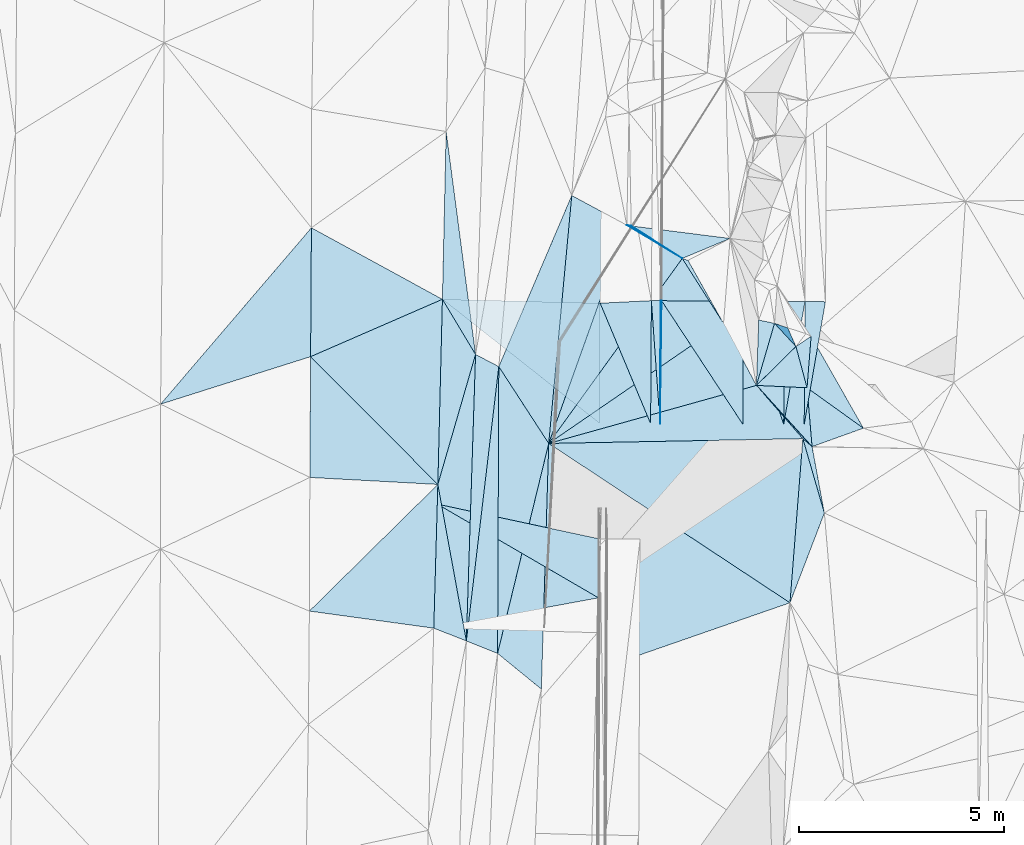
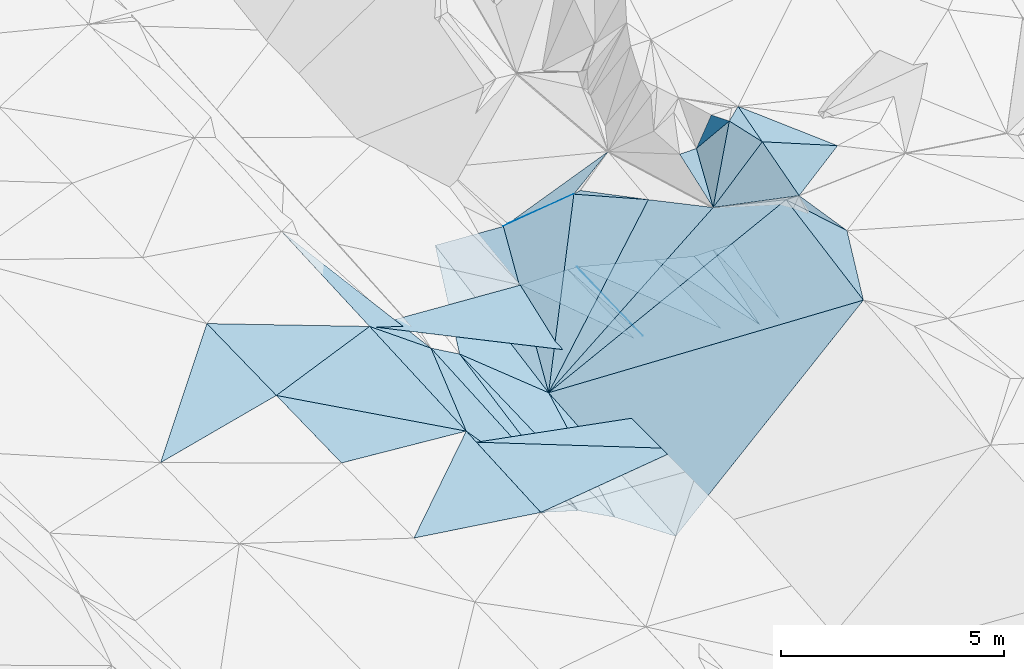
# One storey, part 149 of 275: 45 plates.
"""IFC2X3 building model written with IfcOpenShell, lengths in millimetres."""

from ifc_helpers import new_model, si_unit, frame, origin_with_axes, place, context, subcontext, project, spatial, polyline, outline, extrude, material, type_object, element, save


model = new_model("IFC2X3")

# Units and contexts
model_context = context("Model", 3, precision=1e-05, world=origin_with_axes())
body_context = subcontext(model_context, "Body", "Model", "MODEL_VIEW")
ifc_project = project(units=[si_unit("LENGTHUNIT", "METRE", prefix="MILLI"), si_unit("AREAUNIT", "SQUARE_METRE"), si_unit("VOLUMEUNIT", "CUBIC_METRE"), si_unit("MASSUNIT", "GRAM", prefix="KILO"), si_unit("TIMEUNIT", "SECOND"), si_unit("PLANEANGLEUNIT", "RADIAN"), si_unit("SOLIDANGLEUNIT", "STERADIAN"), si_unit("THERMODYNAMICTEMPERATUREUNIT", "DEGREE_CELSIUS"), si_unit("LUMINOUSINTENSITYUNIT", "LUMEN")], contexts=[model_context])

# Site, building, storey
site_placement = place(None, origin_with_axes())
site = spatial("IfcSite", under=ifc_project, at=site_placement, CompositionType="ELEMENT")
building_placement = place(site_placement, origin_with_axes())
building = spatial("IfcBuilding", under=site, at=building_placement, Name="Undefined", CompositionType="ELEMENT")
storey_placement = place(building_placement, origin_with_axes())
storey = spatial("IfcBuildingStorey", under=building, at=storey_placement, Name="Undefined", CompositionType="ELEMENT", Elevation=0.0)

# Plates
ifc_material = material()
plate_type_1 = type_object("IfcPlateType", PredefinedType="NOTDEFINED")
plate_1_placement = place(storey_placement, frame((-61479.0299583362, 116961.351164867, 43422.3183398899), z_axis=(-0.0329025764102247, 0.0165529434712929, -0.999321480069355), x_axis=(0.977091128612706, -0.209814882884495, -0.0356460559741826)))
element("IfcPlate", 1, at=plate_1_placement, inside=storey, type_object=plate_type_1, material=ifc_material, Name="00_PR", context=body_context, shape_type="SweptSolid", body=[
    extrude(outline(polyline([(0.0, 0.0), (4036.2109375, -5.28234522789717e-09), (4332.94677734375, 1411.77331542969), (0.0, 0.0)])), frame((-8.85201319254618e-08, 2.18876761149539e-07, -0.5000001331573), z_axis=(0.0, 0.0, 1.0), x_axis=(1.0, 0.0, 0.0)), (0.0, 0.0, 1.0), 1.0),
])
plate_type_2 = type_object("IfcPlateType", PredefinedType="NOTDEFINED")
plate_2_placement = place(storey_placement, frame((-57542.1886862768, 114672.084322915, 43254.7783387415), z_axis=(-0.031873229045309, 0.018323285685146, -0.999323948713292), x_axis=(-0.983091266962488, -0.180957062021271, 0.0280375199816376)))
element("IfcPlate", 2, at=plate_2_placement, inside=storey, type_object=plate_type_2, material=ifc_material, Name="00_PR", context=body_context, shape_type="SweptSolid", body=[
    extrude(outline(polyline([(0.0, 0.0), (4091.7314453125, -9.50240064412355e-09), (3460.7119140625, 2964.96264648438), (0.0, 0.0)])), frame((-8.85201319254618e-08, 2.18876761149539e-07, -0.5000001331573), z_axis=(0.0, 0.0, 1.0), x_axis=(1.0, 0.0, 0.0)), (0.0, 0.0, 1.0), 1.0),
])
plate_type_3 = type_object("IfcPlateType", PredefinedType="NOTDEFINED")
plate_3_placement = place(storey_placement, frame((-56039.4487513482, 118925.746862372, 43232.5547125161), z_axis=(-0.049807936925527, 0.0189963330926102, -0.998578143536227), x_axis=(0.00611291887596567, 0.999806175663685, 0.0187147890068687)))
element("IfcPlate", 3, at=plate_3_placement, inside=storey, type_object=plate_type_3, material=ifc_material, Name="00_PR", context=body_context, shape_type="SweptSolid", body=[
    extrude(outline(polyline([(0.0, 0.0), (3002.86572265625, -1.22745404951274e-08), (3002.84252929688, 20.0255527496338), (0.0, 0.0)])), frame((-8.85201319254618e-08, 2.18876761149539e-07, -0.5000001331573), z_axis=(0.0, 0.0, 1.0), x_axis=(1.0, 0.0, 0.0)), (0.0, 0.0, 1.0), 1.0),
])
plate_type_4 = type_object("IfcPlateType", PredefinedType="NOTDEFINED")
plate_4_placement = place(storey_placement, frame((-52326.8632892654, 118364.443197118, 46106.6760373091), z_axis=(0.69734426175413, 0.306468340372365, -0.647910593329046), x_axis=(-0.675138660117306, 0.584351626503173, -0.450245451079859)))
element("IfcPlate", 4, at=plate_4_placement, inside=storey, type_object=plate_type_4, material=ifc_material, Name="00", context=body_context, shape_type="SweptSolid", body=[
    extrude(outline(polyline([(0.0, 0.0), (333.151611328125, 4.94765117764473e-10), (2131.0087890625, 332.806030273438), (0.0, 0.0)])), frame((-8.85201319254618e-08, 2.18876761149539e-07, -0.5000001331573), z_axis=(0.0, 0.0, 1.0), x_axis=(1.0, 0.0, 0.0)), (0.0, 0.0, 1.0), 1.0),
])
plate_type_5 = type_object("IfcPlateType", PredefinedType="NOTDEFINED")
plate_5_placement = place(storey_placement, frame((-52519.4841683663, 118905.108407117, 42481.5540900035), z_axis=(0.000119182844558376, 0.0187254283032671, -0.999824656692517), x_axis=(0.00611306091589654, 0.999805968495159, 0.0187258069971578)))
element("IfcPlate", 5, at=plate_5_placement, inside=storey, type_object=plate_type_5, material=ifc_material, Name="00_PR", context=body_context, shape_type="SweptSolid", body=[
    extrude(outline(polyline([(0.0, 0.0), (3001.09887695313, 1.39043550007045e-08), (3000.97387695313, 499.999359130859), (0.0, 0.0)])), frame((-8.85201319254618e-08, 2.18876761149539e-07, -0.5000001331573), z_axis=(0.0, 0.0, 1.0), x_axis=(1.0, 0.0, 0.0)), (0.0, 0.0, 1.0), 1.0),
])
plate_6_placement = place(storey_placement, frame((-53019.475938482, 118908.03920349, 42481.5540895607), z_axis=(0.000119191142338227, 0.0187238562221799, -0.999824686133346), x_axis=(0.00611294987966392, 0.999805998615529, 0.0187242349956666)))
element("IfcPlate", 6, at=plate_6_placement, inside=storey, type_object=plate_type_5, material=ifc_material, Name="00_PR", context=body_context, shape_type="SweptSolid", body=[
    extrude(outline(polyline([(0.0, 0.0), (3001.35107421875, -6.88305590301752e-09), (3001.22509765625, 500.000671386719), (0.0, 0.0)])), frame((-8.85201319254618e-08, 2.18876761149539e-07, -0.5000001331573), z_axis=(0.0, 0.0, 1.0), x_axis=(1.0, 0.0, 0.0)), (0.0, 0.0, 1.0), 1.0),
])
plate_type_6 = type_object("IfcPlateType", PredefinedType="NOTDEFINED")
plate_7_placement = place(storey_placement, frame((-56021.0924717084, 121928.030640684, 43288.7527128769), z_axis=(-0.0498090880856332, 0.0189963390593034, -0.998578086003504), x_axis=(-0.00611291892662742, -0.999806175663324, -0.0187147890096435)))
element("IfcPlate", 7, at=plate_7_placement, inside=storey, type_object=plate_type_6, material=ifc_material, Name="00_PR", context=body_context, shape_type="SweptSolid", body=[
    extrude(outline(polyline([(0.0, 0.0), (3002.86572265625, -1.22745404951274e-08), (-0.273052126169205, 230.286712646484), (0.0, 0.0)])), frame((-8.85201319254618e-08, 2.18876761149539e-07, -0.5000001331573), z_axis=(0.0, 0.0, 1.0), x_axis=(1.0, 0.0, 0.0)), (0.0, 0.0, 1.0), 1.0),
])
plate_type_7 = type_object("IfcPlateType", PredefinedType="NOTDEFINED")
plate_8_placement = place(storey_placement, frame((-53001.2500793911, 121908.808364038, 42537.76701002), z_axis=(-0.242375710257185, 0.0196476411927777, -0.969983497422964), x_axis=(-0.00611294987499495, -0.999805998615407, -0.0187242350037056)))
element("IfcPlate", 8, at=plate_8_placement, inside=storey, type_object=plate_type_7, material=ifc_material, Name="00_PR", context=body_context, shape_type="SweptSolid", body=[
    extrude(outline(polyline([(0.0, 0.0), (3001.35107421875, -6.88305590301752e-09), (-4.93210220336914, 1030.7646484375), (0.0, 0.0)])), frame((-8.85201319254618e-08, 2.18876761149539e-07, -0.5000001331573), z_axis=(0.0, 0.0, 1.0), x_axis=(1.0, 0.0, 0.0)), (0.0, 0.0, 1.0), 1.0),
])
plate_type_8 = type_object("IfcPlateType", PredefinedType="NOTDEFINED")
plate_9_placement = place(storey_placement, frame((-56001.1885805339, 121927.90407813, 43287.767009768), z_axis=(-0.242375843046882, 0.0196446149122441, -0.969983525536523), x_axis=(0.970122823768883, -0.00617525688061389, -0.242535714906376)))
element("IfcPlate", 9, at=plate_9_placement, inside=storey, type_object=plate_type_8, material=ifc_material, Name="00_PR", context=body_context, shape_type="SweptSolid", body=[
    extrude(outline(polyline([(0.0, 0.0), (2061.55200195313, 4.42378222942352e-09), (2075.91357421875, 3001.81860351563), (0.0, 0.0)])), frame((-8.85201319254618e-08, 2.18876761149539e-07, -0.5000001331573), z_axis=(0.0, 0.0, 1.0), x_axis=(1.0, 0.0, 0.0)), (0.0, 0.0, 1.0), 1.0),
])
plate_type_9 = type_object("IfcPlateType", PredefinedType="NOTDEFINED")
plate_10_placement = place(storey_placement, frame((-56251.0828946079, 121929.494670942, 43300.2525091687), z_axis=(-0.0408545503344278, 0.018948494490378, -0.998985415445851), x_axis=(-0.00611291892662742, -0.999806175663324, -0.0187147890096435)))
element("IfcPlate", 10, at=plate_10_placement, inside=storey, type_object=plate_type_9, material=ifc_material, Name="00_PR", context=body_context, shape_type="SweptSolid", body=[
    extrude(outline(polyline([(0.0, 0.0), (3002.98217773438, -1.09139364212751e-08), (68.4931945800781, 1251.06701660156), (0.0, 0.0)])), frame((-8.85201319254618e-08, 2.18876761149539e-07, -0.5000001331573), z_axis=(0.0, 0.0, 1.0), x_axis=(1.0, 0.0, 0.0)), (0.0, 0.0, 1.0), 1.0),
])
plate_type_10 = type_object("IfcPlateType", PredefinedType="NOTDEFINED")
plate_11_placement = place(storey_placement, frame((-61354.0244489155, 121962.646774277, 43509.5005061315), z_axis=(-0.0408421664010008, 0.0187129023914797, -0.998990362680121), x_axis=(0.998843591986472, -0.0246173179426941, -0.0412972929484572)))
element("IfcPlate", 11, at=plate_11_placement, inside=storey, type_object=plate_type_10, material=ifc_material, Name="00_PR", context=body_context, shape_type="SweptSolid", body=[
    extrude(outline(polyline([(0.0, 0.0), (3856.98413085938, -1.36642483994365e-08), (3913.53466796875, 2933.28540039063), (0.0, 0.0)])), frame((-8.85201319254618e-08, 2.18876761149539e-07, -0.5000001331573), z_axis=(0.0, 0.0, 1.0), x_axis=(1.0, 0.0, 0.0)), (0.0, 0.0, 1.0), 1.0),
])
plate_type_11 = type_object("IfcPlateType", PredefinedType="NOTDEFINED")
plate_12_placement = place(storey_placement, frame((-53243.7252866068, 121375.65325235, 45889.7370056535), z_axis=(0.848332088537827, -0.0605051250467132, -0.525996005118034), x_axis=(0.439041433956534, -0.474876256974329, 0.762715648083505)))
element("IfcPlate", 12, at=plate_12_placement, inside=storey, type_object=plate_type_11, material=ifc_material, Name="00", context=body_context, shape_type="SweptSolid", body=[
    extrude(outline(polyline([(0.0, 0.0), (1193.10522460938, 8.58562998473644e-10), (115.672950744629, 1664.21655273438), (0.0, 0.0)])), frame((-8.85201319254618e-08, 2.18876761149539e-07, -0.5000001331573), z_axis=(0.0, 0.0, 1.0), x_axis=(1.0, 0.0, 0.0)), (0.0, 0.0, 1.0), 1.0),
])
plate_type_12 = type_object("IfcPlateType", PredefinedType="NOTDEFINED")
plate_13_placement = place(storey_placement, frame((-56850.7797211205, 123771.838198348, 43569.5740240012), z_axis=(0.517243051542686, -0.0818251017264593, -0.851917999785346), x_axis=(0.745046776028475, -0.446782143451001, 0.495268631979561)))
element("IfcPlate", 13, at=plate_13_placement, inside=storey, type_object=plate_type_12, material=ifc_material, Name="00", context=body_context, shape_type="SweptSolid", body=[
    extrude(outline(polyline([(0.0, 0.0), (1817.19567871094, -3.20869730785489e-09), (640.206237792969, 5660.76513671875), (0.0, 0.0)])), frame((-8.85201319254618e-08, 2.18876761149539e-07, -0.5000001331573), z_axis=(0.0, 0.0, 1.0), x_axis=(1.0, 0.0, 0.0)), (0.0, 0.0, 1.0), 1.0),
])
plate_type_13 = type_object("IfcPlateType", PredefinedType="NOTDEFINED")
plate_14_placement = place(storey_placement, frame((-55496.9757153138, 122959.791961986, 44469.57160676), z_axis=(0.333751542116307, -0.393172210884728, -0.856752893618109), x_axis=(-0.745046776033763, 0.446782143438528, -0.495268631982857)))
element("IfcPlate", 14, at=plate_14_placement, inside=storey, type_object=plate_type_13, material=ifc_material, Name="00", context=body_context, shape_type="SweptSolid", body=[
    extrude(outline(polyline([(0.0, 0.0), (1817.19567871094, -3.20869730785489e-09), (1704.76965332031, 39.5018882751465), (0.0, 0.0)])), frame((-8.85201319254618e-08, 2.18876761149539e-07, -0.5000001331573), z_axis=(0.0, 0.0, 1.0), x_axis=(1.0, 0.0, 0.0)), (0.0, 0.0, 1.0), 1.0),
])
plate_type_14 = type_object("IfcPlateType", PredefinedType="NOTDEFINED")
plate_15_placement = place(storey_placement, frame((-53685.6383279684, 119859.603387808, 45351.5511689026), z_axis=(0.439352055737474, -0.0345783696349237, -0.89764921181531), x_axis=(0.620062306166801, -0.711360945492197, 0.330890226056248)))
element("IfcPlate", 15, at=plate_15_placement, inside=storey, type_object=plate_type_14, material=ifc_material, Name="00", context=body_context, shape_type="SweptSolid", body=[
    extrude(outline(polyline([(0.0, 0.0), (1828.40100097656, -8.21455614641309e-09), (-2940.55419921875, 4998.3291015625), (0.0, 0.0)])), frame((-8.85201319254618e-08, 2.18876761149539e-07, -0.5000001331573), z_axis=(0.0, 0.0, 1.0), x_axis=(1.0, 0.0, 0.0)), (0.0, 0.0, 1.0), 1.0),
])
plate_type_15 = type_object("IfcPlateType", PredefinedType="NOTDEFINED")
plate_16_placement = place(storey_placement, frame((-61354.0255894502, 121962.646826846, 43509.500540234), z_axis=(-0.0428705906760543, 0.0187319073889793, -0.998905014553765), x_axis=(0.514898006455965, -0.856401789479594, -0.0381578029218377)))
element("IfcPlate", 16, at=plate_16_placement, inside=storey, type_object=plate_type_15, material=ifc_material, Name="00", context=body_context, shape_type="SweptSolid", body=[
    extrude(outline(polyline([(0.0, 0.0), (1572.41760253906, 2.65936250798404e-09), (3817.580078125, 2426.00122070313), (0.0, 0.0)])), frame((-8.85201319254618e-08, 2.18876761149539e-07, -0.5000001331573), z_axis=(0.0, 0.0, 1.0), x_axis=(1.0, 0.0, 0.0)), (0.0, 0.0, 1.0), 1.0),
])
plate_type_16 = type_object("IfcPlateType", PredefinedType="NOTDEFINED")
plate_17_placement = place(storey_placement, frame((-54328.5172688935, 123447.989110163, 44928.5668156013), z_axis=(0.439464793612823, -0.23726843262176, -0.866356962259814), x_axis=(-0.867483975671943, -0.362404622485834, -0.340785037161698)))
element("IfcPlate", 17, at=plate_17_placement, inside=storey, type_object=plate_type_16, material=ifc_material, Name="00", context=body_context, shape_type="SweptSolid", body=[
    extrude(outline(polyline([(0.0, 0.0), (1346.89013671875, 4.43833414465189e-09), (2431.05419921875, 1316.2021484375), (0.0, 0.0)])), frame((-8.85201319254618e-08, 2.18876761149539e-07, -0.5000001331573), z_axis=(0.0, 0.0, 1.0), x_axis=(1.0, 0.0, 0.0)), (0.0, 0.0, 1.0), 1.0),
])
plate_type_17 = type_object("IfcPlateType", PredefinedType="NOTDEFINED")
plate_18_placement = place(storey_placement, frame((-60768.8324343098, 113619.908639251, 43329.5214232664), z_axis=(-0.288471439383598, 0.0256666360911163, -0.957144426119549), x_axis=(0.0320421244614618, 0.9993395254752, 0.0171410350620224)))
element("IfcPlate", 18, at=plate_18_placement, inside=storey, type_object=plate_type_17, material=ifc_material, Name="00", context=body_context, shape_type="SweptSolid", body=[
    extrude(outline(polyline([(0.0, 0.0), (7000.744140625, 3.45753505825996e-08), (6719.1708984375, 602.461242675781), (0.0, 0.0)])), frame((-8.85201319254618e-08, 2.18876761149539e-07, -0.5000001331573), z_axis=(0.0, 0.0, 1.0), x_axis=(1.0, 0.0, 0.0)), (0.0, 0.0, 1.0), 1.0),
])
plate_type_18 = type_object("IfcPlateType", PredefinedType="NOTDEFINED")
plate_19_placement = place(storey_placement, frame((-58757.8588323389, 118442.712989502, 42923.5467483449), z_axis=(0.422201868177247, 0.0054583395439276, -0.906485404756782), x_axis=(0.563995640327622, 0.781288582001737, 0.267389359035006)))
element("IfcPlate", 19, at=plate_19_placement, inside=storey, type_object=plate_type_18, material=ifc_material, Name="00", context=body_context, shape_type="SweptSolid", body=[
    extrude(outline(polyline([(0.0, 0.0), (5781.83056640625, -1.91066646948457e-08), (5232.783203125, 1856.91857910156), (0.0, 0.0)])), frame((-8.85201319254618e-08, 2.18876761149539e-07, -0.5000001331573), z_axis=(0.0, 0.0, 1.0), x_axis=(1.0, 0.0, 0.0)), (0.0, 0.0, 1.0), 1.0),
])
plate_type_19 = type_object("IfcPlateType", PredefinedType="NOTDEFINED")
plate_20_placement = place(storey_placement, frame((-58195.2576853498, 124497.366959812, 43083.5115053436), z_axis=(-0.208550369623353, 0.0452068689817732, -0.976966264682065), x_axis=(-0.0925415685314663, -0.995361334486497, -0.0263034580045142)))
element("IfcPlate", 20, at=plate_20_placement, inside=storey, type_object=plate_type_19, material=ifc_material, Name="00", context=body_context, shape_type="SweptSolid", body=[
    extrude(outline(polyline([(0.0, 0.0), (6082.8505859375, -4.78758011013269e-09), (4318.79541015625, 1419.48449707031), (0.0, 0.0)])), frame((-8.85201319254618e-08, 2.18876761149539e-07, -0.5000001331573), z_axis=(0.0, 0.0, 1.0), x_axis=(1.0, 0.0, 0.0)), (0.0, 0.0, 1.0), 1.0),
])
plate_type_20 = type_object("IfcPlateType", PredefinedType="NOTDEFINED")
plate_21_placement = place(storey_placement, frame((-52026.585026435, 116742.306012551, 46029.5150487687), z_axis=(0.241580302858253, 0.0308979401134254, -0.96988879494902), x_axis=(-0.355493649307203, -0.927189514081666, -0.118084166081877)))
element("IfcPlate", 21, at=plate_21_placement, inside=storey, type_object=plate_type_20, material=ifc_material, Name="00", context=body_context, shape_type="SweptSolid", body=[
    extrude(outline(polyline([(0.0, 0.0), (2362.72143554688, -1.17579475045204e-08), (-1488.99694824219, 1168.16491699219), (0.0, 0.0)])), frame((-8.85201319254618e-08, 2.18876761149539e-07, -0.5000001331573), z_axis=(0.0, 0.0, 1.0), x_axis=(1.0, 0.0, 0.0)), (0.0, 0.0, 1.0), 1.0),
])
plate_type_21 = type_object("IfcPlateType", PredefinedType="NOTDEFINED")
plate_22_placement = place(storey_placement, frame((-61465.4521778604, 117441.520184333, 43429.5005394583), z_axis=(-0.0430301649422816, 0.0182932295498284, -0.998906283220642), x_axis=(0.179300305610219, -0.983457755689404, -0.0257340860036582)))
element("IfcPlate", 22, at=plate_22_placement, inside=storey, type_object=plate_type_21, material=ifc_material, Name="00", context=body_context, shape_type="SweptSolid", body=[
    extrude(outline(polyline([(0.0, 0.0), (3885.89672851563, 1.0113581083715e-08), (3435.54418945313, 727.7607421875), (0.0, 0.0)])), frame((-8.85201319254618e-08, 2.18876761149539e-07, -0.5000001331573), z_axis=(0.0, 0.0, 1.0), x_axis=(1.0, 0.0, 0.0)), (0.0, 0.0, 1.0), 1.0),
])
plate_type_22 = type_object("IfcPlateType", PredefinedType="NOTDEFINED")
plate_23_placement = place(storey_placement, frame((-61262.7224877274, 126059.398080829, 43589.5004991977), z_axis=(-0.0400996297586528, 0.0204015742651627, -0.998987385035828), x_axis=(0.130787930620647, -0.991082628668625, -0.0254900050069909)))
element("IfcPlate", 23, at=plate_23_placement, inside=storey, type_object=plate_type_22, material=ifc_material, Name="00", context=body_context, shape_type="SweptSolid", body=[
    extrude(outline(polyline([(0.0, 0.0), (5492.34912109375, -3.39496182277799e-08), (4050.31616210938, 626.927917480469), (0.0, 0.0)])), frame((-8.85201319254618e-08, 2.18876761149539e-07, -0.5000001331573), z_axis=(0.0, 0.0, 1.0), x_axis=(1.0, 0.0, 0.0)), (0.0, 0.0, 1.0), 1.0),
])
plate_type_23 = type_object("IfcPlateType", PredefinedType="NOTDEFINED")
plate_24_placement = place(storey_placement, frame((-52350.1986471895, 121060.248840798, 46919.5063526397), z_axis=(0.0973306377261847, 0.125701945800875, -0.987282010259322), x_axis=(0.493403001659141, -0.867601001971799, -0.0618221589018055)))
element("IfcPlate", 24, at=plate_24_placement, inside=storey, type_object=plate_type_23, material=ifc_material, Name="00", context=body_context, shape_type="SweptSolid", body=[
    extrude(outline(polyline([(0.0, 0.0), (2588.06884765625, -1.41735654324293e-08), (1052.48364257813, 716.434387207031), (0.0, 0.0)])), frame((-8.85201319254618e-08, 2.18876761149539e-07, -0.5000001331573), z_axis=(0.0, 0.0, 1.0), x_axis=(1.0, 0.0, 0.0)), (0.0, 0.0, 1.0), 1.0),
])
plate_type_24 = type_object("IfcPlateType", PredefinedType="NOTDEFINED")
plate_25_placement = place(storey_placement, frame((-53243.7062194962, 121375.867140537, 45889.8592003227), z_axis=(0.88646026113915, 0.367268047516023, -0.281606794475699), x_axis=(0.344390943856289, -0.116999202989138, 0.931507415048147)))
element("IfcPlate", 25, at=plate_25_placement, inside=storey, type_object=plate_type_24, material=ifc_material, Name="00", context=body_context, shape_type="SweptSolid", body=[
    extrude(outline(polyline([(0.0, 0.0), (933.970031738281, 5.23868948221207e-10), (1094.36059570313, 475.262939453125), (0.0, 0.0)])), frame((-8.85201319254618e-08, 2.18876761149539e-07, -0.5000001331573), z_axis=(0.0, 0.0, 1.0), x_axis=(1.0, 0.0, 0.0)), (0.0, 0.0, 1.0), 1.0),
])
plate_type_25 = type_object("IfcPlateType", PredefinedType="NOTDEFINED")
plate_26_placement = place(storey_placement, frame((-53685.7448533624, 119859.753933926, 45351.531543104), z_axis=(0.226028689532777, 0.266627872733768, -0.936920812550112), x_axis=(0.0336519708339458, 0.959100542387471, 0.281058169159074)))
element("IfcPlate", 26, at=plate_26_placement, inside=storey, type_object=plate_type_25, material=ifc_material, Name="00", context=body_context, shape_type="SweptSolid", body=[
    extrude(outline(polyline([(0.0, 0.0), (1665.1357421875, 5.03496266901493e-09), (1620.13037109375, 397.711608886719), (0.0, 0.0)])), frame((-8.85201319254618e-08, 2.18876761149539e-07, -0.5000001331573), z_axis=(0.0, 0.0, 1.0), x_axis=(1.0, 0.0, 0.0)), (0.0, 0.0, 1.0), 1.0),
])
plate_type_26 = type_object("IfcPlateType", PredefinedType="NOTDEFINED")
plate_27_placement = place(storey_placement, frame((-52719.9598177586, 120809.220537808, 46799.6802863823), z_axis=(0.734036682068431, 0.228720384971688, -0.639435012238438), x_axis=(0.258862859251788, -0.964725005363351, -0.047913298014975)))
element("IfcPlate", 27, at=plate_27_placement, inside=storey, type_object=plate_type_26, material=ifc_material, Name="00", context=body_context, shape_type="SweptSolid", body=[
    extrude(outline(polyline([(0.0, 0.0), (1043.55163574219, -4.10000211559236e-09), (735.430786132813, 1841.09167480469), (0.0, 0.0)])), frame((-8.85201319254618e-08, 2.18876761149539e-07, -0.5000001331573), z_axis=(0.0, 0.0, 1.0), x_axis=(1.0, 0.0, 0.0)), (0.0, 0.0, 1.0), 1.0),
])
plate_type_27 = type_object("IfcPlateType", PredefinedType="NOTDEFINED")
plate_28_placement = place(storey_placement, frame((-52450.0397007069, 119802.571127342, 46749.5696102747), z_axis=(0.300755742631578, 0.410598995128739, -0.860787109843891), x_axis=(0.812576607038931, -0.582824527847819, 0.00590147710885984)))
element("IfcPlate", 28, at=plate_28_placement, inside=storey, type_object=plate_type_27, material=ifc_material, Name="00", context=body_context, shape_type="SweptSolid", body=[
    extrude(outline(polyline([(0.0, 0.0), (1694.49108886719, -1.13504938781261e-09), (934.280517578125, 1274.26647949219), (0.0, 0.0)])), frame((-8.85201319254618e-08, 2.18876761149539e-07, -0.5000001331573), z_axis=(0.0, 0.0, 1.0), x_axis=(1.0, 0.0, 0.0)), (0.0, 0.0, 1.0), 1.0),
])
plate_type_28 = type_object("IfcPlateType", PredefinedType="NOTDEFINED")
plate_29_placement = place(storey_placement, frame((-52326.8556214931, 118364.458065837, 46106.6920447028), z_axis=(0.712415985499923, 0.336315452038892, -0.615918322770194), x_axis=(-0.629924405906405, 0.693297062758218, -0.350049175994302)))
element("IfcPlate", 29, at=plate_29_placement, inside=storey, type_object=plate_type_28, material=ifc_material, Name="00", context=body_context, shape_type="SweptSolid", body=[
    extrude(outline(polyline([(0.0, 0.0), (2156.83984375, 8.01810529083014e-09), (849.399169921875, 1332.34985351563), (0.0, 0.0)])), frame((-8.85201319254618e-08, 2.18876761149539e-07, -0.5000001331573), z_axis=(0.0, 0.0, 1.0), x_axis=(1.0, 0.0, 0.0)), (0.0, 0.0, 1.0), 1.0),
])
plate_type_29 = type_object("IfcPlateType", PredefinedType="NOTDEFINED")
plate_30_placement = place(storey_placement, frame((-58758.1857939334, 118442.724899088, 42923.5138266057), z_axis=(-0.231728705573477, 0.029296136826433, -0.972339212096421), x_axis=(-0.236449249359129, -0.971266208670962, 0.0270869778941756)))
element("IfcPlate", 30, at=plate_30_placement, inside=storey, type_object=plate_type_29, material=ifc_material, Name="00", context=body_context, shape_type="SweptSolid", body=[
    extrude(outline(polyline([(0.0, 0.0), (5279.28955078125, 4.52564563602209e-09), (-1524.921875, 1673.75012207031), (0.0, 0.0)])), frame((-8.85201319254618e-08, 2.18876761149539e-07, -0.5000001331573), z_axis=(0.0, 0.0, 1.0), x_axis=(1.0, 0.0, 0.0)), (0.0, 0.0, 1.0), 1.0),
])
plate_type_30 = type_object("IfcPlateType", PredefinedType="NOTDEFINED")
plate_31_placement = place(storey_placement, frame((-58758.2151605746, 118442.732285804, 42923.5220519762), z_axis=(-0.290441751418028, 0.0440485626356174, -0.955878294116445), x_axis=(-0.0298523394217043, -0.998870791680332, -0.0369591579849714)))
element("IfcPlate", 31, at=plate_31_placement, inside=storey, type_object=plate_type_30, material=ifc_material, Name="00", context=body_context, shape_type="SweptSolid", body=[
    extrude(outline(polyline([(0.0, 0.0), (6006.63037109375, -2.18278728425503e-09), (5153.78466796875, 1144.29187011719), (0.0, 0.0)])), frame((-8.85201319254618e-08, 2.18876761149539e-07, -0.5000001331573), z_axis=(0.0, 0.0, 1.0), x_axis=(1.0, 0.0, 0.0)), (0.0, 0.0, 1.0), 1.0),
])
plate_type_31 = type_object("IfcPlateType", PredefinedType="NOTDEFINED")
plate_32_placement = place(storey_placement, frame((-61465.4493738549, 117441.519629671, 43429.5004176427), z_axis=(-0.0374184731790921, 0.0171782847789726, -0.999152022665719), x_axis=(-0.997780888082568, 0.0544623014134893, 0.0383034868113674)))
element("IfcPlate", 32, at=plate_32_placement, inside=storey, type_object=plate_type_31, material=ifc_material, Name="00", context=body_context, shape_type="SweptSolid", body=[
    extrude(outline(polyline([(0.0, 0.0), (3132.8740234375, 6.43194653093815e-09), (3276.48022460938, 2946.53637695313), (0.0, 0.0)])), frame((-8.85201319254618e-08, 2.18876761149539e-07, -0.5000001331573), z_axis=(0.0, 0.0, 1.0), x_axis=(1.0, 0.0, 0.0)), (0.0, 0.0, 1.0), 1.0),
])
plate_type_32 = type_object("IfcPlateType", PredefinedType="NOTDEFINED")
plate_33_placement = place(storey_placement, frame((-64572.3801652994, 120561.692864608, 43599.5004012493), z_axis=(-0.0360242658032513, 0.018568011957981, -0.999178403091893), x_axis=(0.916594973307161, 0.398994543834439, -0.0256321848150462)))
element("IfcPlate", 33, at=plate_33_placement, inside=storey, type_object=plate_type_32, material=ifc_material, Name="00", context=body_context, shape_type="SweptSolid", body=[
    extrude(outline(polyline([(0.0, 0.0), (3511.21069335938, 8.00355337560177e-09), (1607.22338867188, 4102.9541015625), (0.0, 0.0)])), frame((-8.85201319254618e-08, 2.18876761149539e-07, -0.5000001331573), z_axis=(0.0, 0.0, 1.0), x_axis=(1.0, 0.0, 0.0)), (0.0, 0.0, 1.0), 1.0),
])
plate_type_33 = type_object("IfcPlateType", PredefinedType="NOTDEFINED")
plate_34_placement = place(storey_placement, frame((-60544.3904820501, 120616.025483916, 43449.5005205821), z_axis=(-0.0420053418137465, 0.0184811227137273, -0.998946444691782), x_axis=(-0.0320421244554766, -0.999339525475748, -0.0171410350412605)))
element("IfcPlate", 34, at=plate_34_placement, inside=storey, type_object=plate_type_33, material=ifc_material, Name="00", context=body_context, shape_type="SweptSolid", body=[
    extrude(outline(polyline([(0.0, 0.0), (7000.744140625, 3.45753505825996e-08), (3202.26416015625, 819.598449707031), (0.0, 0.0)])), frame((-8.85201319254618e-08, 2.18876761149539e-07, -0.5000001331573), z_axis=(0.0, 0.0, 1.0), x_axis=(1.0, 0.0, 0.0)), (0.0, 0.0, 1.0), 1.0),
])
plate_type_34 = type_object("IfcPlateType", PredefinedType="NOTDEFINED")
plate_35_placement = place(storey_placement, frame((-52551.8170233807, 118559.044585931, 45956.6222937095), z_axis=(0.636945524503394, 0.153866674035246, -0.755397541322732), x_axis=(0.675138660108836, -0.584351626513641, 0.450245451078973)))
element("IfcPlate", 35, at=plate_35_placement, inside=storey, type_object=plate_type_34, material=ifc_material, Name="00", context=body_context, shape_type="SweptSolid", body=[
    extrude(outline(polyline([(0.0, 0.0), (333.151611328125, 4.94765117764473e-10), (1449.18395996094, 1217.20446777344), (0.0, 0.0)])), frame((-8.85201319254618e-08, 2.18876761149539e-07, -0.5000001331573), z_axis=(0.0, 0.0, 1.0), x_axis=(1.0, 0.0, 0.0)), (0.0, 0.0, 1.0), 1.0),
])
plate_type_35 = type_object("IfcPlateType", PredefinedType="NOTDEFINED")
plate_36_placement = place(storey_placement, frame((-54488.7554479605, 121372.025709987, 44929.5501400306), z_axis=(0.436103012818509, -0.0194566655690106, -0.899686390013517), x_axis=(0.455370123612511, -0.857545972877653, 0.239275897077926)))
element("IfcPlate", 36, at=plate_36_placement, inside=storey, type_object=plate_type_35, material=ifc_material, Name="00", context=body_context, shape_type="SweptSolid", body=[
    extrude(outline(polyline([(0.0, 0.0), (1763.65441894531, -9.42964106798172e-09), (88.0246124267578, 5551.7939453125), (0.0, 0.0)])), frame((-8.85201319254618e-08, 2.18876761149539e-07, -0.5000001331573), z_axis=(0.0, 0.0, 1.0), x_axis=(1.0, 0.0, 0.0)), (0.0, 0.0, 1.0), 1.0),
])
plate_type_36 = type_object("IfcPlateType", PredefinedType="NOTDEFINED")
plate_37_placement = place(storey_placement, frame((-55496.8870588157, 122960.026773116, 44469.5719308375), z_axis=(0.511077634696213, 0.0764725023293923, -0.856125929814537), x_axis=(0.835455652349227, -0.278302801618798, 0.47387910227067)))
element("IfcPlate", 37, at=plate_37_placement, inside=storey, type_object=plate_type_36, material=ifc_material, Name="00", context=body_context, shape_type="SweptSolid", body=[
    extrude(outline(polyline([(0.0, 0.0), (168.819427490234, 4.51109372079372e-10), (1502.19677734375, 1221.8857421875), (0.0, 0.0)])), frame((-8.85201319254618e-08, 2.18876761149539e-07, -0.5000001331573), z_axis=(0.0, 0.0, 1.0), x_axis=(1.0, 0.0, 0.0)), (0.0, 0.0, 1.0), 1.0),
])
plate_type_37 = type_object("IfcPlateType", PredefinedType="NOTDEFINED")
plate_38_placement = place(storey_placement, frame((-60006.511813353, 113315.129113391, 43066.5257681707), z_axis=(-0.315629867884192, 0.0289533087858432, -0.948440558184728), x_axis=(-0.884277272249351, 0.353534013557844, 0.305069511818093)))
element("IfcPlate", 38, at=plate_38_placement, inside=storey, type_object=plate_type_37, material=ifc_material, Name="00", context=body_context, shape_type="SweptSolid", body=[
    extrude(outline(polyline([(0.0, 0.0), (862.098571777344, -3.75439412891865e-09), (2512.31591796875, 6541.17724609375), (0.0, 0.0)])), frame((-8.85201319254618e-08, 2.18876761149539e-07, -0.5000001331573), z_axis=(0.0, 0.0, 1.0), x_axis=(1.0, 0.0, 0.0)), (0.0, 0.0, 1.0), 1.0),
])
plate_type_38 = type_object("IfcPlateType", PredefinedType="NOTDEFINED")
plate_39_placement = place(storey_placement, frame((-64553.0080469409, 123708.217445979, 43649.5005868869), z_axis=(-0.0460114718372274, 0.0161549871897122, -0.99881027269861), x_axis=(-0.00615736333973573, -0.999854814892599, -0.015888235043266)))
element("IfcPlate", 39, at=plate_39_placement, inside=storey, type_object=plate_type_38, material=ifc_material, Name="00", context=body_context, shape_type="SweptSolid", body=[
    extrude(outline(polyline([(0.0, 0.0), (3146.98266601563, 1.75205059349537e-08), (4327.44677734375, 3660.30126953125), (0.0, 0.0)])), frame((-8.85201319254618e-08, 2.18876761149539e-07, -0.5000001331573), z_axis=(0.0, 0.0, 1.0), x_axis=(1.0, 0.0, 0.0)), (0.0, 0.0, 1.0), 1.0),
])
plate_type_39 = type_object("IfcPlateType", PredefinedType="NOTDEFINED")
plate_40_placement = place(storey_placement, frame((-52350.1286987268, 121060.241777787, 46919.5174792373), z_axis=(0.237213887431188, 0.111579519842513, -0.96502828060192), x_axis=(-0.0784983373235507, -0.987931935920505, -0.133523410029111)))
element("IfcPlate", 40, at=plate_40_placement, inside=storey, type_object=plate_type_39, material=ifc_material, Name="00", context=body_context, shape_type="SweptSolid", body=[
    extrude(outline(polyline([(0.0, 0.0), (1273.18493652344, 1.60071067512035e-10), (293.123168945313, 358.439422607422), (0.0, 0.0)])), frame((-8.85201319254618e-08, 2.18876761149539e-07, -0.5000001331573), z_axis=(0.0, 0.0, 1.0), x_axis=(1.0, 0.0, 0.0)), (0.0, 0.0, 1.0), 1.0),
])
plate_type_40 = type_object("IfcPlateType", PredefinedType="NOTDEFINED")
plate_41_placement = place(storey_placement, frame((-61465.447515251, 117441.520055652, 43429.5003579219), z_axis=(-0.0337035957649128, 0.0180356008540115, -0.999269125278246), x_axis=(-0.0282727293378718, -0.999454222824265, -0.0170853520458629)))
element("IfcPlate", 41, at=plate_41_placement, inside=storey, type_object=plate_type_40, material=ifc_material, Name="00", context=body_context, shape_type="SweptSolid", body=[
    extrude(outline(polyline([(0.0, 0.0), (3511.7802734375, -5.92262949794531e-09), (3178.84350585938, 3050.48413085938), (0.0, 0.0)])), frame((-8.85201319254618e-08, 2.18876761149539e-07, -0.5000001331573), z_axis=(0.0, 0.0, 1.0), x_axis=(1.0, 0.0, 0.0)), (0.0, 0.0, 1.0), 1.0),
])
plate_type_41 = type_object("IfcPlateType", PredefinedType="NOTDEFINED")
plate_42_placement = place(storey_placement, frame((-52551.9160581209, 118558.973525895, 45956.5507602369), z_axis=(0.438884003185546, 0.0117418592635375, -0.898467005787561), x_axis=(-0.0781380234339212, -0.995627941929882, -0.0511805680146971)))
element("IfcPlate", 42, at=plate_42_placement, inside=storey, type_object=plate_type_41, material=ifc_material, Name="00", context=body_context, shape_type="SweptSolid", body=[
    extrude(outline(polyline([(0.0, 0.0), (4024.96508789063, -3.688910510391e-09), (755.899230957031, 6866.9384765625), (0.0, 0.0)])), frame((-8.85201319254618e-08, 2.18876761149539e-07, -0.5000001331573), z_axis=(0.0, 0.0, 1.0), x_axis=(1.0, 0.0, 0.0)), (0.0, 0.0, 1.0), 1.0),
])
plate_type_42 = type_object("IfcPlateType", PredefinedType="NOTDEFINED")
plate_43_placement = place(storey_placement, frame((-61354.0216228384, 121962.645504903, 43509.5003658117), z_axis=(-0.0349495949676334, 0.0160940029890894, -0.999259480254946), x_axis=(-0.916594973346173, -0.39899454374404, 0.0256321848271439)))
element("IfcPlate", 43, at=plate_43_placement, inside=storey, type_object=plate_type_42, material=ifc_material, Name="00", context=body_context, shape_type="SweptSolid", body=[
    extrude(outline(polyline([(0.0, 0.0), (3511.21069335938, 8.00355337560177e-09), (2239.28466796875, 2878.48999023438), (0.0, 0.0)])), frame((-8.85201319254618e-08, 2.18876761149539e-07, -0.5000001331573), z_axis=(0.0, 0.0, 1.0), x_axis=(1.0, 0.0, 0.0)), (0.0, 0.0, 1.0), 1.0),
])
plate_type_43 = type_object("IfcPlateType", PredefinedType="NOTDEFINED")
plate_44_placement = place(storey_placement, frame((-58937.1603079981, 112442.872533474, 42701.5518904686), z_axis=(0.443195962512313, 0.0199149790044967, -0.896203510606846), x_axis=(0.0298523394336849, 0.998870791679237, 0.0369591580048874)))
element("IfcPlate", 44, at=plate_44_placement, inside=storey, type_object=plate_type_43, material=ifc_material, Name="00", context=body_context, shape_type="SweptSolid", body=[
    extrude(outline(polyline([(0.0, 0.0), (6006.63037109375, -2.18278728425503e-09), (2400.2705078125, 6695.9541015625), (0.0, 0.0)])), frame((-8.85201319254618e-08, 2.18876761149539e-07, -0.5000001331573), z_axis=(0.0, 0.0, 1.0), x_axis=(1.0, 0.0, 0.0)), (0.0, 0.0, 1.0), 1.0),
])
plate_type_44 = type_object("IfcPlateType", PredefinedType="NOTDEFINED")
plate_45_placement = place(storey_placement, frame((-58757.9014604581, 118442.707035709, 42923.5292408776), z_axis=(0.336945320250617, -0.00644658978725387, -0.941502146912753), x_axis=(0.0925415684735771, 0.995361334491043, 0.0263034580361519)))
element("IfcPlate", 45, at=plate_45_placement, inside=storey, type_object=plate_type_44, material=ifc_material, Name="00", context=body_context, shape_type="SweptSolid", body=[
    extrude(outline(polyline([(0.0, 0.0), (6082.8505859375, -4.78758011013269e-09), (5497.92041015625, 1492.31286621094), (0.0, 0.0)])), frame((-8.85201319254618e-08, 2.18876761149539e-07, -0.5000001331573), z_axis=(0.0, 0.0, 1.0), x_axis=(1.0, 0.0, 0.0)), (0.0, 0.0, 1.0), 1.0),
])

save(model, "model.ifc")
